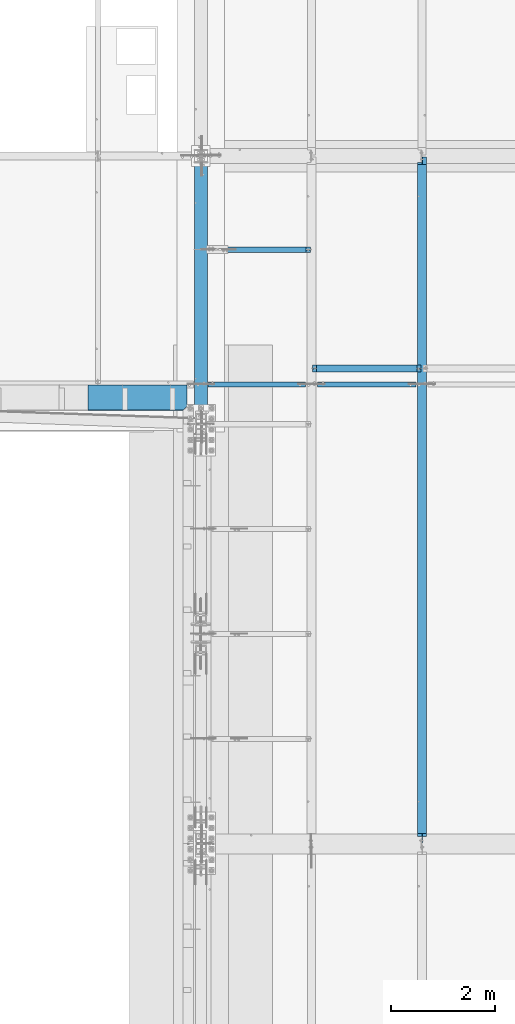
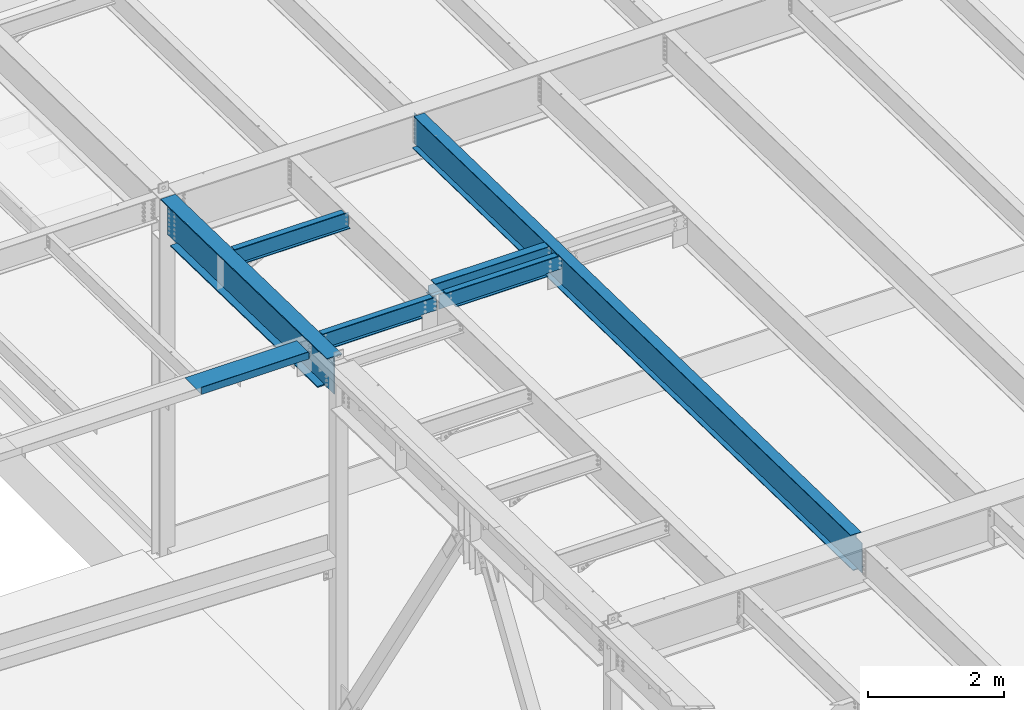
# One storey, part 1049 of 1763: 7 beams, 7 elements without a shape of their own.
"""IFC2X3 building model written with IfcOpenShell, lengths in millimetres."""

from ifc_helpers import new_model, si_unit, frame, origin_with_axes, place, context, subcontext, project, spatial, faceted_brep, material, type_object, element, aggregate, save


model = new_model("IFC2X3")

# Units and contexts
model_context = context("Model", 3, precision=1e-05, world=origin_with_axes())
body_context = subcontext(model_context, "Body", "Model", "MODEL_VIEW")
ifc_project = project(units=[si_unit("LENGTHUNIT", "METRE", prefix="MILLI"), si_unit("AREAUNIT", "SQUARE_METRE"), si_unit("VOLUMEUNIT", "CUBIC_METRE"), si_unit("MASSUNIT", "GRAM", prefix="KILO"), si_unit("TIMEUNIT", "SECOND"), si_unit("PLANEANGLEUNIT", "RADIAN"), si_unit("SOLIDANGLEUNIT", "STERADIAN"), si_unit("THERMODYNAMICTEMPERATUREUNIT", "DEGREE_CELSIUS"), si_unit("LUMINOUSINTENSITYUNIT", "LUMEN")], contexts=[model_context])

# Site, building, storey
site_placement = place(None, origin_with_axes())
site = spatial("IfcSite", under=ifc_project, at=site_placement, CompositionType="ELEMENT")
building_placement = place(site_placement, origin_with_axes())
building = spatial("IfcBuilding", under=site, at=building_placement, Name="Undefined", CompositionType="ELEMENT")
storey_placement = place(building_placement, origin_with_axes())
storey = spatial("IfcBuildingStorey", under=building, at=storey_placement, Name="Undefined", CompositionType="ELEMENT", Elevation=0.0)

# Assembly, beam
assembly_1_placement = place(storey_placement, origin_with_axes())
assembly_1 = element("IfcElementAssembly", 1, at=assembly_1_placement, inside=storey, Name="BEAM", AssemblyPlace="NOTDEFINED", PredefinedType="RIGID_FRAME")
ifc_material_1 = material(Name="STEEL/A992")
beam_type_1 = type_object("IfcBeamType", Name="W8X18", PredefinedType="NOTDEFINED")
beam_1_placement = place(assembly_1_placement, frame((-85249.0944165555, 9601.2, 11614.0449111666), z_axis=(0.0, 0.0, 1.0), x_axis=(1.0, 0.0, 0.0)))
beam_1 = element("IfcBeam", 2, at=beam_1_placement, type_object=beam_type_1, material=ifc_material_1, Name="BEAM", ObjectType="W8X18", context=body_context, shape_type="Brep", body=[
    faceted_brep([(87.3125001907465, -3.17499999999927, 66.4150016680069), (87.3125001907465, 3.17499999999927, 66.4150016680069), (17.4625000000087, 3.17499999999927, 66.4150016680069), (17.4625000000087, -3.17499999999927, 66.4150016680069), (92.1725797087856, -3.17499999999927, 67.3817315905944), (92.1725797087856, 3.17499999999927, 67.3817315905944), (96.2927561769466, -3.17499999999927, 70.134745491072), (96.2927561769466, 3.17499999999927, 70.134745491072), (99.0457700774277, -3.17499999999927, 74.2549219592256), (99.0457700774277, 3.17499999999927, 74.2549219592256), (100.012500000012, -3.17499999999927, 79.115001477272), (100.012500000012, 3.17499999999927, 79.115001477272), (100.012500000012, -66.6749999999993, 103.11874512049), (100.012500000001, 66.6749999999993, 103.1875), (100.012500000001, 66.6749999999993, 95.25), (100.012500000001, 3.17499999999927, 95.25), (100.012500000001, -3.17499999999927, 95.25), (100.012500000001, -66.6749999999993, 95.25), (17.4624999999905, -3.17500000000018, -95.25), (17.4624999999905, -66.6750000000002, -95.25), (2108.88035714286, -66.6750000000002, -95.25), (2108.88035714286, -3.17500000000018, -95.25), (17.4624999999905, -66.6750000000002, -103.1875), (2108.88035714286, -66.6750000000002, -103.1875), (17.4624999999905, 66.6750000000002, -103.1875), (2108.88035714286, 66.6750000000002, -103.1875), (17.4624999999905, 66.6750000000002, -95.25), (2108.88035714286, 66.6750000000002, -95.25), (17.4624999999905, 3.17500000000018, -95.25), (2108.88035714286, 3.17500000000018, -95.25), (2108.88035714287, 3.17499999999927, 66.4150016740186), (2108.88035714287, -3.17499999999927, 66.4150016740186), (2039.03035695213, 3.17499999999927, 66.4150016740186), (2039.03035695213, -3.17499999999927, 66.4150016740186), (2034.1702774341, 3.17499999999927, 67.3817315966062), (2034.1702774341, -3.17499999999927, 67.3817315966062), (2030.05010096593, 3.17499999999927, 70.1347454970837), (2030.05010096593, -3.17499999999927, 70.1347454970837), (2027.29708706545, 3.17499999999927, 74.2549219652374), (2027.29708706545, -3.17499999999927, 74.2549219652374), (2026.33035714287, 3.17499999999927, 79.1150014832838), (2026.33035714287, -3.17499999999927, 79.1150014832838), (2026.33035714287, -66.6749999999993, 103.1875), (2026.33035714287, -66.6749999999993, 95.25), (2026.33035714287, -3.17499999999927, 95.25), (2026.33035714287, 3.17499999999927, 95.25), (2026.33035714287, 66.6749999999993, 95.25), (2026.33035714287, 66.6749999999993, 103.1875)], [[[0, 1, 2, 3]], [[4, 5, 1, 0]], [[6, 7, 5, 4]], [[8, 9, 7, 6]], [[10, 11, 9, 8]], [[12, 13, 14, 15, 11, 10, 16, 17]], [[18, 19, 20, 21]], [[19, 22, 23, 20]], [[22, 24, 25, 23]], [[24, 26, 27, 25]], [[26, 28, 29, 27]], [[21, 20, 23, 25, 27, 29, 30, 31]], [[31, 30, 32, 33]], [[33, 32, 34, 35]], [[35, 34, 36, 37]], [[37, 36, 38, 39]], [[39, 38, 40, 41]], [[42, 43, 44, 41, 40, 45, 46, 47]], [[43, 42, 12, 17]], [[44, 43, 17, 16]], [[8, 6, 4, 0, 3, 18, 21, 31, 33, 35, 37, 39, 41, 44, 16, 10]], [[28, 26, 24, 22, 19, 18, 3, 2]], [[45, 40, 38, 36, 34, 32, 30, 29, 28, 2, 1, 5, 7, 9, 11, 15]], [[46, 45, 15, 14]], [[47, 46, 14, 13]], [[42, 47, 13, 12]]]),
])
aggregate(assembly_1, [beam_1])

assembly_2_placement = place(storey_placement, origin_with_axes())
assembly_2 = element("IfcElementAssembly", 3, at=assembly_2_placement, inside=storey, Name="BEAM", AssemblyPlace="NOTDEFINED", PredefinedType="RIGID_FRAME")
ifc_material_2 = material(Name="STEEL/A36")
beam_type_2 = type_object("IfcBeamType", PredefinedType="NOTDEFINED")
beam_2_placement = place(assembly_2_placement, frame((-88600.9872736984, 9283.7, 11725.1920365109), z_axis=(-1.0, 0.0, 0.0), x_axis=(0.0, -1.0, 0.0)))
beam_2 = element("IfcBeam", 4, at=beam_2_placement, type_object=beam_type_2, material=ifc_material_2, Name="BENT_PLATE", context=body_context, shape_type="Brep", body=[
    faceted_brep([(0.0, -3.17499999999927, -952.5), (0.0, -3.17499999999927, 952.5), (0.0, 3.17499999999927, 952.5), (0.0, 3.17499999999927, -952.5), (482.600012207033, 3.17499999999927, 952.5), (488.950012207031, -3.17499999999927, 952.5), (488.950012207031, 123.825000000001, 952.5), (482.600012207033, 123.825000000001, 952.5), (488.950012207031, -3.17499999999927, -876.300003120254), (488.950012207031, 123.825000000001, -876.300003120254), (482.600012207033, 123.825000000001, -882.824358372673), (482.600012207033, 3.17499999999927, -882.824358372673), (414.786365154396, 3.17499999999927, -952.5), (414.786365154396, -3.17499999999927, -952.5)], [[[0, 1, 2, 3]], [[4, 2, 1, 5, 6, 7]], [[6, 5, 8, 9]], [[7, 6, 9, 10]], [[4, 7, 10, 11]], [[3, 2, 4, 11, 12]], [[0, 3, 12, 13]], [[5, 1, 0, 13, 8]], [[12, 11, 10, 9, 8, 13]]]),
])
aggregate(assembly_2, [beam_2])

assembly_3_placement = place(storey_placement, origin_with_axes())
assembly_3 = element("IfcElementAssembly", 5, at=assembly_3_placement, inside=storey, Name="BEAM", AssemblyPlace="NOTDEFINED", PredefinedType="RIGID_FRAME")
beam_type_3 = type_object("IfcBeamType", Name="W12X22", PredefinedType="NOTDEFINED")
beam_3_placement = place(assembly_3_placement, frame((-87375.4372736983, 11887.2, 11513.8664710857), z_axis=(0.0, 0.0, 1.0), x_axis=(1.0, 0.0, 0.0)))
beam_3 = element("IfcBeam", 6, at=beam_3_placement, type_object=beam_type_3, material=ifc_material_1, Name="BEAM", ObjectType="W12X22", context=body_context, shape_type="Brep", body=[
    faceted_brep([(20.6374999999971, -3.17499999999927, -123.824999999781), (20.6374999999971, 3.17499999999927, -123.824999999781), (128.587500190726, 3.17500001968983, -123.824999999781), (128.587500190726, -3.17499999999927, -123.824999999781), (133.447579708765, 3.17500001977351, -124.791729922368), (133.447579708765, -3.17499999999927, -124.791729922368), (137.567756176926, 3.17500002000997, -127.544743822846), (137.567756176926, -3.17499999999927, -127.544743822846), (140.320770077407, 3.17500002036286, -131.664920290999), (140.320770077407, -3.17499999999927, -131.664920290999), (141.287499999991, -3.17499999999927, -136.524999809046), (141.287499999991, 3.17500002077941, -136.524999809046), (141.287500000006, 3.17500004903195, -144.4625), (141.287500000006, 3.17500004903195, -155.575000000001), (141.287499999991, -50.7999999999993, -155.575000000001), (141.287499999991, -50.7999999999993, -144.4625), (141.287499999991, -3.17499999999927, -144.4625), (2108.88035714286, 50.7999999999993, -144.4625), (2108.88035714286, 50.7999999999993, -155.575000000001), (141.287500000006, 50.7999999999993, -155.575000000001), (141.287500000006, 50.7999999999993, -144.4625), (2019.98035714286, 50.7999999999993, 144.4625), (2019.98035714286, 3.17499999999927, 144.4625), (141.287499999991, 3.17499999999927, 144.4625), (141.287499999991, 50.7999999999993, 144.4625), (128.587500190726, -3.17499999999927, 111.12500000022), (128.587500190726, 3.17499999968095, 111.12500000022), (20.6374999999971, 3.17499999999927, 111.12500000022), (20.6374999999971, -3.17499999999927, 111.12500000022), (133.447579708765, -3.17499999999927, 112.091729922808), (133.447579708765, 3.17499999959728, 112.091729922808), (137.567756176926, -3.17499999999927, 114.844743823285), (137.567756176926, 3.17499999936263, 114.844743823285), (140.320770077407, -3.17499999999927, 118.964920291439), (140.320770077407, 3.17499999901156, 118.964920291439), (141.287499999991, -3.17499999999927, 123.824999809485), (141.287499999991, 3.17499999859865, 123.824999809485), (2019.98035714286, -50.7999999999993, 155.575000000001), (2019.98035714286, 50.7999999999993, 155.575000000001), (141.287499999991, 50.7999999999993, 155.575000000001), (141.287499999991, -50.7999999999993, 155.575000000001), (2019.98035714286, -50.7999999999993, 144.4625), (141.287499999991, -50.7999999999993, 144.4625), (2019.98035714286, -3.17499999999927, 144.4625), (141.287499999991, -3.17499999999927, 144.4625), (2019.98035714286, -3.17499999999927, 129.915001480787), (2019.98035714286, 3.17499999999927, 129.915001480787), (2020.94708706545, -3.17499999999927, 125.054921962741), (2020.94708706545, 3.17499999999927, 125.054921962741), (2023.70010096593, -3.17499999999927, 120.934745494587), (2023.70010096593, 3.17499999999927, 120.934745494587), (2027.82027743409, -3.17499999999927, 118.18173159411), (2027.82027743409, 3.17499999999927, 118.18173159411), (2032.68035695213, -3.17499999999927, 117.215001671522), (2032.68035695213, 3.17499999999927, 117.215001671522), (2108.88035714286, -3.17499999999927, 117.215001671522), (2108.88035714286, 3.17499999999927, 117.215001671522), (2108.88035714286, -3.17499999999927, -144.4625), (2108.88035714286, -50.7999999999993, -144.4625), (2108.88035714286, -50.7999999999993, -155.575000000001), (2108.88035714286, 3.17499999999927, -144.4625)], [[[0, 1, 2, 3]], [[3, 2, 4, 5]], [[5, 4, 6, 7]], [[7, 6, 8, 9]], [[10, 11, 12, 13, 14, 15, 16]], [[9, 8, 11, 10]], [[17, 18, 19, 20]], [[21, 22, 23, 24]], [[25, 26, 27, 28]], [[29, 30, 26, 25]], [[31, 32, 30, 29]], [[33, 34, 32, 31]], [[35, 36, 34, 33]], [[37, 38, 39, 40]], [[41, 37, 40, 42]], [[43, 41, 42, 44]], [[40, 39, 24, 23, 36, 35, 44, 42]], [[38, 21, 24, 39]], [[37, 41, 43, 45, 46, 22, 21, 38]], [[47, 48, 46, 45]], [[49, 50, 48, 47]], [[51, 52, 50, 49]], [[53, 54, 52, 51]], [[55, 56, 54, 53]], [[57, 58, 59, 18, 17, 60, 56, 55]], [[58, 57, 16, 15]], [[59, 58, 15, 14]], [[19, 18, 59, 14, 13]], [[20, 19, 13, 12]], [[60, 17, 20, 12]], [[6, 4, 2, 1, 27, 26, 30, 32, 34, 36, 23, 22, 46, 48, 50, 52, 54, 56, 60, 12, 11, 8]], [[28, 27, 1, 0]], [[57, 55, 53, 51, 49, 47, 45, 43, 44, 35, 33, 31, 29, 25, 28, 0, 3, 5, 7, 9, 10, 16]]]),
])
aggregate(assembly_3, [beam_3])

assembly_4_placement = place(storey_placement, origin_with_axes())
assembly_4 = element("IfcElementAssembly", 7, at=assembly_4_placement, inside=storey, Name="BEAM", AssemblyPlace="NOTDEFINED", PredefinedType="RIGID_FRAME")
beam_4_placement = place(assembly_4_placement, frame((-85249.0944165555, 9296.39999999999, 11568.0295365109), z_axis=(0.0, 0.0, 1.0), x_axis=(1.0, 0.0, 0.0)))
beam_4 = element("IfcBeam", 8, at=beam_4_placement, type_object=beam_type_3, material=ifc_material_1, Name="BEAM", ObjectType="W12X22", context=body_context, shape_type="Brep", body=[
    faceted_brep([(1842.18035714286, -3.17499999999927, -144.4625), (1842.18035714286, -50.7999999999993, -144.4625), (1842.18035714286, -50.7999999999993, -155.575000000001), (1842.18035714286, 50.7999999999993, -155.575000000001), (1842.18035714286, 50.7999999999993, -144.4625), (1842.18035714286, 3.17499999999927, -144.4625), (1842.18035714286, 3.17499999999927, -142.874999813543), (1842.18035714286, -3.17499999999927, -142.874999813543), (1843.14708706544, 3.17499999999927, -138.014920295496), (1843.14708706544, -3.17499999999927, -138.014920295496), (1845.90010096593, 3.17499999999927, -133.894743827343), (1845.90010096593, -3.17499999999927, -133.894743827343), (1850.02027743409, 3.17499999999927, -131.141729926865), (1850.02027743409, -3.17499999999927, -131.141729926865), (1854.88035695213, 3.17499999999927, -130.175000004278), (1854.88035695213, -3.17499999999927, -130.175000004278), (2108.88035714287, -3.17499999999927, -130.175000004278), (2108.88035714287, 3.17499999999927, -130.175000004278), (2013.63035714286, 50.7999999999993, 144.4625), (2013.63035714286, 3.17499999999927, 144.4625), (112.712499999994, 3.17499999999927, 144.4625), (112.712499999994, 50.7999999999993, 144.4625), (284.162499999991, -3.17499999999927, -142.874999813543), (284.162499999991, 3.17500002591078, -142.874999813543), (284.162499999991, 3.17500009460491, -144.4625), (284.162499999991, 50.7999999999993, -144.4625), (284.162499999991, 50.7999999999993, -155.575000000001), (284.162499999991, -50.7999999999993, -155.575000000001), (284.162499999991, -50.7999999999993, -144.4625), (284.162499999991, -3.17499999999927, -144.4625), (283.195770077407, -3.17499999999927, -138.014920295496), (283.195770077407, 3.17500002519773, -138.014920295496), (280.442756176926, -3.17499999999927, -133.894743827343), (280.442756176926, 3.17500002459201, -133.894743827343), (276.322579708765, -3.17499999999927, -131.141729926865), (276.322579708765, 3.17500002418637, -131.141729926865), (271.462500190726, -3.17499999999927, -130.175000004278), (271.462500190726, 3.17500002404267, -130.175000004278), (17.4625000000087, -3.17499999999927, -130.175000004278), (17.4625000000087, 3.17499999999927, -130.175000004278), (17.4625000000087, -3.17499999999927, 130.174999995723), (17.4625000000087, 3.17499999999927, 130.174999995723), (100.012500190729, -3.17499999999927, 130.174999995723), (100.012500190729, 3.1749999863805, 130.174999995723), (104.872579708768, -3.17499999999927, 131.14172991831), (104.872579708768, 3.17499998624044, 131.14172991831), (108.992756176929, -3.17499999999927, 133.894743818788), (108.992756176929, 3.17499998584026, 133.894743818788), (111.74577007741, -3.17499999999927, 138.014920286942), (111.74577007741, 3.17499998524181, 138.014920286942), (112.712499999994, -3.17499999999927, 142.874999804988), (112.712499999994, 3.17499998453604, 142.874999804988), (112.712499999994, -50.7999999999993, 155.575000000001), (112.712499999994, 50.7999999999993, 155.575000000001), (112.712499999994, -3.17499999999927, 144.4625), (112.712499999994, -50.7999999999993, 144.4625), (2013.63035714286, -3.17499999999927, 144.4625), (2013.63035714286, -50.7999999999993, 144.4625), (2013.63035714286, -50.7999999999993, 155.575000000001), (2013.63035714286, 50.7999999999993, 155.575000000001), (2013.63035714286, -3.17499999999927, 142.874999804988), (2013.63035714286, 3.17499999999927, 142.874999804988), (2014.59708706544, -3.17499999999927, 138.014920286942), (2014.59708706544, 3.17499999999927, 138.014920286942), (2017.35010096592, -3.17499999999927, 133.894743818788), (2017.35010096592, 3.17499999999927, 133.894743818788), (2021.47027743408, -3.17499999999927, 131.14172991831), (2021.47027743408, 3.17499999999927, 131.14172991831), (2026.33035695212, -3.17499999999927, 130.174999995723), (2026.33035695212, 3.17499999999927, 130.174999995723), (2108.88035714287, -3.17499999999927, 130.174999995723), (2108.88035714287, 3.17499999999927, 130.174999995723)], [[[0, 1, 2, 3, 4, 5, 6, 7]], [[7, 6, 8, 9]], [[9, 8, 10, 11]], [[11, 10, 12, 13]], [[13, 12, 14, 15]], [[16, 15, 14, 17]], [[18, 19, 20, 21]], [[22, 23, 24, 25, 26, 27, 28, 29]], [[30, 31, 23, 22]], [[32, 33, 31, 30]], [[34, 35, 33, 32]], [[36, 37, 35, 34]], [[38, 39, 37, 36]], [[40, 41, 39, 38]], [[42, 43, 41, 40]], [[44, 45, 43, 42]], [[46, 47, 45, 44]], [[48, 49, 47, 46]], [[50, 51, 49, 48]], [[52, 53, 21, 20, 51, 50, 54, 55]], [[56, 57, 55, 54]], [[57, 58, 52, 55]], [[58, 59, 53, 52]], [[59, 18, 21, 53]], [[58, 57, 56, 60, 61, 19, 18, 59]], [[62, 63, 61, 60]], [[64, 65, 63, 62]], [[66, 67, 65, 64]], [[68, 69, 67, 66]], [[70, 71, 69, 68]], [[71, 70, 16, 17]], [[33, 35, 37, 39, 41, 43, 45, 47, 49, 51, 20, 19, 61, 63, 65, 67, 69, 71, 17, 14, 12, 10, 8, 6, 5, 24, 23, 31]], [[5, 4, 25, 24]], [[4, 3, 26, 25]], [[3, 2, 27, 26]], [[2, 1, 28, 27]], [[1, 0, 29, 28]], [[0, 7, 9, 11, 13, 15, 16, 70, 68, 66, 64, 62, 60, 56, 54, 50, 48, 46, 44, 42, 40, 38, 36, 34, 32, 30, 22, 29]]]),
])
aggregate(assembly_4, [beam_4])

assembly_5_placement = place(storey_placement, origin_with_axes())
assembly_5 = element("IfcElementAssembly", 9, at=assembly_5_placement, inside=storey, Name="BEAM", AssemblyPlace="NOTDEFINED", PredefinedType="RIGID_FRAME")
beam_5_placement = place(assembly_5_placement, frame((-87375.4372736983, 9296.4, 11568.0295365109), z_axis=(0.0, 0.0, 1.0), x_axis=(1.0, 0.0, 0.0)))
beam_5 = element("IfcBeam", 10, at=beam_5_placement, type_object=beam_type_3, material=ifc_material_1, Name="BEAM", ObjectType="W12X22", context=body_context, shape_type="Brep", body=[
    faceted_brep([(19.0500000000029, -3.17499999999927, -130.17499999858), (19.0500000000029, 3.17499999999927, -130.17499999858), (273.050000190749, 3.17500002409361, -130.17499999858), (273.050000190749, -3.17499999999927, -130.17499999858), (277.910079708789, 3.17500002423913, -131.141729921168), (277.910079708789, -3.17499999999927, -131.141729921168), (282.030256176949, 3.1750000246484, -133.894743821646), (282.030256176949, -3.17499999999927, -133.894743821646), (284.783270077431, 3.1750000252614, -138.014920289799), (284.783270077431, -3.17499999999927, -138.014920289799), (285.750000000015, -3.17499999999927, -142.874999807846), (285.750000000015, 3.17500002598354, -142.874999807846), (285.750000000015, 3.1750000952652, -144.4625), (285.750000000015, 50.7999999999993, -144.4625), (285.750000000015, 50.7999999999993, -155.575000000001), (285.750000000015, -50.7999999999993, -155.575000000001), (285.750000000015, -50.7999999999993, -144.4625), (285.750000000015, -3.17499999999927, -144.4625), (2013.63035714286, 50.7999999999993, 144.4625), (2013.63035714286, 3.17499999999927, 144.4625), (139.700000000012, 3.17499999999927, 144.4625), (139.700000000012, 50.7999999999993, 144.4625), (127.000000190747, -3.17499999999927, 117.475000001421), (127.000000190747, 3.17499998809399, 117.475000001421), (19.0500000000029, 3.17499999999927, 117.475000001421), (19.0500000000029, -3.17499999999927, 117.475000001421), (131.860079708786, -3.17499999999927, 118.441729924009), (131.860079708786, 3.17499998795211, 118.441729924009), (135.980256176947, -3.17499999999927, 121.194743824486), (135.980256176947, 3.17499998755011, 121.194743824486), (138.733270077428, -3.17499999999927, 125.31492029264), (138.733270077428, 3.17499998694802, 125.31492029264), (139.700000000012, -3.17499999999927, 130.174999810686), (139.700000000012, 3.1749999862368, 130.174999810686), (2013.63035714286, -50.7999999999993, 155.575000000001), (2013.63035714286, 50.7999999999993, 155.575000000001), (139.700000000012, 50.7999999999993, 155.575000000001), (139.700000000012, -50.7999999999993, 155.575000000001), (2013.63035714286, -50.7999999999993, 144.4625), (139.700000000012, -50.7999999999993, 144.4625), (2013.63035714286, -3.17499999999927, 144.4625), (139.700000000012, -3.17499999999927, 144.4625), (2013.63035714286, -3.17499999999927, 142.874999804988), (2013.63035714286, 3.17499999999927, 142.874999804988), (2014.59708706544, -3.17499999999927, 138.014920286942), (2014.59708706544, 3.17499999999927, 138.014920286942), (2017.35010096592, -3.17499999999927, 133.894743818788), (2017.35010096592, 3.17499999999927, 133.894743818788), (2021.47027743408, -3.17499999999927, 131.14172991831), (2021.47027743408, 3.17499999999927, 131.14172991831), (2026.33035695212, -3.17499999999927, 130.174999995723), (2026.33035695212, 3.17499999999927, 130.174999995723), (2108.88035714287, -3.17499999999927, 130.174999995723), (2108.88035714287, 3.17499999999927, 130.174999995723), (2108.88035714287, -3.17499999999927, -130.175000004278), (2108.88035714287, 3.17499999999927, -130.175000004278), (1854.88035695213, -3.17499999999927, -130.175000004278), (1854.88035695213, 3.17499999999927, -130.175000004278), (1850.02027743409, -3.17499999999927, -131.141729926865), (1850.02027743409, 3.17499999999927, -131.141729926865), (1845.90010096593, -3.17499999999927, -133.894743827343), (1845.90010096593, 3.17499999999927, -133.894743827343), (1843.14708706544, -3.17499999999927, -138.014920295496), (1843.14708706544, 3.17499999999927, -138.014920295496), (1842.18035714286, -3.17499999999927, -142.874999813543), (1842.18035714286, 3.17499999999927, -142.874999813543), (1842.18035714286, -3.17499999999927, -144.4625), (1842.18035714286, -50.7999999999993, -144.4625), (1842.18035714286, -50.7999999999993, -155.575000000001), (1842.18035714286, 50.7999999999993, -155.575000000001), (1842.18035714286, 50.7999999999993, -144.4625), (1842.18035714286, 3.17499999999927, -144.4625)], [[[0, 1, 2, 3]], [[3, 2, 4, 5]], [[5, 4, 6, 7]], [[7, 6, 8, 9]], [[10, 11, 12, 13, 14, 15, 16, 17]], [[9, 8, 11, 10]], [[18, 19, 20, 21]], [[22, 23, 24, 25]], [[26, 27, 23, 22]], [[28, 29, 27, 26]], [[30, 31, 29, 28]], [[32, 33, 31, 30]], [[34, 35, 36, 37]], [[38, 34, 37, 39]], [[40, 38, 39, 41]], [[37, 36, 21, 20, 33, 32, 41, 39]], [[35, 18, 21, 36]], [[34, 38, 40, 42, 43, 19, 18, 35]], [[44, 45, 43, 42]], [[46, 47, 45, 44]], [[48, 49, 47, 46]], [[50, 51, 49, 48]], [[52, 53, 51, 50]], [[53, 52, 54, 55]], [[54, 56, 57, 55]], [[58, 59, 57, 56]], [[60, 61, 59, 58]], [[62, 63, 61, 60]], [[64, 65, 63, 62]], [[66, 67, 68, 69, 70, 71, 65, 64]], [[67, 66, 17, 16]], [[68, 67, 16, 15]], [[69, 68, 15, 14]], [[70, 69, 14, 13]], [[71, 70, 13, 12]], [[6, 4, 2, 1, 24, 23, 27, 29, 31, 33, 20, 19, 43, 45, 47, 49, 51, 53, 55, 57, 59, 61, 63, 65, 71, 12, 11, 8]], [[25, 24, 1, 0]], [[66, 64, 62, 60, 58, 56, 54, 52, 50, 48, 46, 44, 42, 40, 41, 32, 30, 28, 26, 22, 25, 0, 3, 5, 7, 9, 10, 17]]]),
])
aggregate(assembly_5, [beam_5])

assembly_6_placement = place(storey_placement, origin_with_axes())
assembly_6 = element("IfcElementAssembly", 11, at=assembly_6_placement, inside=storey, Name="BEAM", AssemblyPlace="NOTDEFINED", PredefinedType="RIGID_FRAME")
beam_type_4 = type_object("IfcBeamType", Name="W24X55", PredefinedType="NOTDEFINED")
beam_6_placement = place(assembly_6_placement, frame((-83122.7515594126, 450.92880941152, 11608.424216848), z_axis=(0.0, 0.0209013539966291, 0.999781542838788), x_axis=(0.0, 0.999781542776098, -0.0209013569953182)))
beam_6 = element("IfcBeam", 12, at=beam_6_placement, type_object=beam_type_4, material=ifc_material_1, Name="BEAM", ObjectType="W24X55", context=body_context, shape_type="Brep", body=[
    faceted_brep([(32.9216259333548, -5.06265067245113, -287.33750000024), (33.1871311560335, -5.06238327905885, -300.03750000025), (153.914585386825, -5.0623648079054, -300.037500000291), (153.914585386861, -5.06263216065418, -287.33750000028), (153.914598213893, -88.8999999999942, -287.33750000028), (153.914598213888, -88.8999999999942, -300.037500000291), (204.714570270236, -4.76249999999709, 248.977497673244), (204.714570270236, 4.76249999999709, 248.977497673244), (203.747840347651, 4.76249999999709, 244.117418155187), (203.747840347651, -4.76249999999709, 244.117418155187), (200.994826447175, 4.76249999999709, 239.997241687024), (200.994826447175, -4.76249999999709, 239.997241687024), (196.874649979021, 4.76249999999709, 237.244227786541), (196.874649979021, -4.76249999999709, 237.244227786541), (192.014570460975, 4.76249999999709, 236.277497863954), (192.014570460975, -4.76249999999709, 236.277497863954), (21.9749710825074, 4.76249999999709, 236.277497863952), (21.9749710825074, -4.76249999999709, 236.277497863952), (32.9216259333548, -4.76249999999709, -287.33750000024), (13228.7230938096, -4.76249999999709, -287.337500004809), (13217.3781810464, -4.76249999999709, 255.32750160553), (13083.0160379566, -4.76249999999709, 255.327501605576), (13078.1559584386, -4.76249999999709, 256.294231528167), (13074.0357819704, -4.76249999999709, 259.047245428657), (13071.2827680699, -4.76249999999709, 263.167421896822), (13070.3160381474, -4.76249999999709, 268.027501414879), (13070.3160381473, -4.76249999999709, 287.337499995707), (204.714570270192, -4.76249999999709, 287.33750000016), (13217.3781810464, 4.76249999999709, 255.32750160553), (13083.0160379566, 4.76249999999709, 255.327501605576), (13078.1559584386, 4.76249999999709, 256.294231528167), (13074.0357819704, 4.76249999999709, 259.047245428657), (13071.2827680699, 4.76249999999709, 263.167421896822), (13070.3160381474, 4.76249999999709, 268.027501414879), (13070.3160381473, -88.8999999999942, 300.037499995717), (13070.3160381473, -88.8999999999942, 287.337499995707), (13070.3160381473, 4.76249999999709, 287.337499995707), (13070.3160381473, 88.8999999999942, 287.337499995707), (13070.3160381473, 88.8999999999942, 300.037499995717), (204.714570270192, 4.76249999999709, 287.33750000016), (204.714570270192, 88.8999999999942, 287.33750000016), (204.714570270192, 88.8999999999942, 300.03750000017), (204.714570270192, -88.8999999999942, 300.03750000017), (204.714570270192, -88.8999999999942, 287.33750000016), (13228.7230938096, 4.76249999999709, -287.337500004809), (32.9216259333548, 4.76249999999709, -287.33750000024), (13127.4660345771, 5.0626322090975, -287.337500004771), (13127.4660345772, 5.06236486541457, -300.037500004782), (13127.4660261933, 88.8999999999942, -300.037500004782), (13127.4660261934, 88.8999999999942, -287.337500004771), (153.914571035813, 88.8999999999942, -300.037500000291), (153.914571035818, 88.8999999999942, -287.337500000282), (153.914583862354, 5.06263212728663, -300.037500000293), (153.914583862389, 5.06236477453785, -287.33750000028), (33.1871311560335, 5.06261365597311, -300.03750000025), (32.9216259333548, 5.06234626258083, -287.33750000024), (13228.7230938096, 5.06264233497495, -287.337500004809), (13228.9885990323, 5.06237501776195, -300.037500004817), (13228.7230938096, -88.8999999999942, -287.337500004809), (13228.9885990323, -88.8999999999942, -300.037500004817)], [[[0, 1, 2, 3]], [[4, 3, 2, 5]], [[6, 7, 8, 9]], [[9, 8, 10, 11]], [[11, 10, 12, 13]], [[13, 12, 14, 15]], [[15, 14, 16, 17]], [[9, 11, 13, 15, 17, 18, 19, 20, 21, 22, 23, 24, 25, 26, 27, 6]], [[20, 28, 29, 21]], [[21, 29, 30, 22]], [[22, 30, 31, 23]], [[23, 31, 32, 24]], [[24, 32, 33, 25]], [[34, 35, 26, 25, 33, 36, 37, 38]], [[37, 36, 39, 40]], [[38, 37, 40, 41]], [[34, 38, 41, 42]], [[35, 34, 42, 43]], [[26, 35, 43, 27]], [[42, 41, 40, 39, 7, 6, 27, 43]], [[36, 33, 32, 31, 30, 29, 28, 44, 45, 16, 14, 12, 10, 8, 7, 39]], [[46, 47, 48, 49]], [[49, 48, 50, 51]], [[51, 50, 52, 53]], [[53, 52, 54, 55]], [[45, 44, 56, 46, 49, 51, 53, 55]], [[57, 47, 46, 56]], [[44, 28, 20, 19, 58, 59, 57, 56]], [[59, 58, 4, 5]], [[1, 54, 52, 50, 48, 47, 57, 59, 5, 2]], [[18, 17, 16, 45, 55, 54, 1, 0]], [[58, 19, 18, 0, 3, 4]]]),
])
aggregate(assembly_6, [beam_6])

assembly_7_placement = place(storey_placement, origin_with_axes())
assembly_7 = element("IfcElementAssembly", 13, at=assembly_7_placement, inside=storey, Name="BEAM", AssemblyPlace="NOTDEFINED", PredefinedType="RIGID_FRAME")
beam_type_5 = type_object("IfcBeamType", Name="W27X94", PredefinedType="NOTDEFINED")
beam_7_placement = place(assembly_7_placement, frame((-87375.4372736983, 8527.26610581684, 11398.296912048), z_axis=(0.0, 0.0209013539966291, 0.999781542838788), x_axis=(0.0, 0.999781542776098, -0.0209013569953182)))
beam_7 = element("IfcBeam", 14, at=beam_7_placement, type_object=beam_type_5, material=ifc_material_1, Name="BEAM", ObjectType="W27X94", context=body_context, shape_type="Brep", body=[
    faceted_brep([(128.197623114129, -6.35000000000582, -322.262500000301), (128.595880948142, -6.35000000000582, -341.312500000317), (407.995874845505, -6.35000000000582, -341.312500000955), (407.99587484551, -6.35000000000582, -322.262500000392), (407.995874845512, -127.0, -322.262500763851), (407.995874845506, -127.0, -341.312500000407), (4745.33127331602, 6.65056916563481, -322.26250000182), (4745.33127331708, 6.64943439267518, -341.312500001837), (4745.33116319688, 127.0, -341.312500001837), (4745.33116319688, 127.0, -322.262500001823), (407.995874845506, 127.0, -341.312500000407), (407.99587484551, 127.0, -322.262500000392), (114.723233063391, -127.0, 322.262500000223), (114.723233063391, -6.35000000000582, 322.262500000223), (5017.99438797338, -6.35000000000582, 322.262499998607), (5017.99438797338, -127.0, 322.262499998607), (114.324975229378, -127.0, 341.312500000238), (5017.59613013937, -127.0, 341.312499998623), (114.324975229378, 127.0, 341.312500000238), (5017.59613013937, 127.0, 341.312499998623), (114.723233063391, 127.0, 322.262500000223), (5017.99438797338, 127.0, 322.262499998607), (114.723233063391, 6.35000000000582, 322.262500000223), (5017.99438797338, 6.35000000000582, 322.262499998607), (5031.46877802412, 6.35000000000582, -322.262500001914), (407.995874845512, 6.35000000000582, -322.262500763851), (128.197623114129, 6.35000000000582, -322.262500000301), (407.995874845505, 6.35000000000582, -341.312500000955), (128.595880948142, 6.35000000000582, -341.312500000317), (5031.46877802412, 6.65083098025934, -322.262500001914), (5031.86703585813, 6.64969657157781, -341.31250000193), (5031.46877802412, -6.35000000000582, -322.262500001914), (5031.46877802412, -6.64917209408304, -322.262500001914), (5031.86703585813, -6.65030650277913, -341.31250000193), (4745.33146831234, -6.64943390995904, -322.262500001822), (4745.33146831339, -6.65056868291867, -341.312500001837), (4745.33157843355, -127.0, -322.262500001822), (4745.33157843354, -127.0, -341.312500001837)], [[[0, 1, 2, 3]], [[4, 3, 2, 5]], [[6, 7, 8, 9]], [[9, 8, 10, 11]], [[12, 13, 14, 15]], [[16, 12, 15, 17]], [[18, 16, 17, 19]], [[20, 18, 19, 21]], [[22, 20, 21, 23]], [[22, 23, 24, 25, 26]], [[25, 27, 28, 26]], [[11, 10, 27, 25]], [[24, 29, 6, 9, 11, 25]], [[30, 7, 6, 29]], [[24, 23, 21, 19, 17, 15, 14, 31, 32, 33, 30, 29]], [[33, 32, 34, 35]], [[36, 37, 35, 34]], [[37, 36, 4, 5]], [[1, 28, 27, 10, 8, 7, 30, 33, 35, 37, 5, 2]], [[13, 12, 16, 18, 20, 22, 26, 28, 1, 0]], [[31, 14, 13, 0, 3]], [[36, 34, 32, 31, 3, 4]]]),
])
aggregate(assembly_7, [beam_7])

save(model, "model.ifc")
